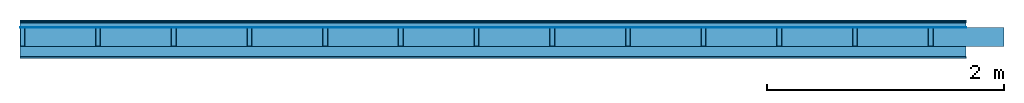
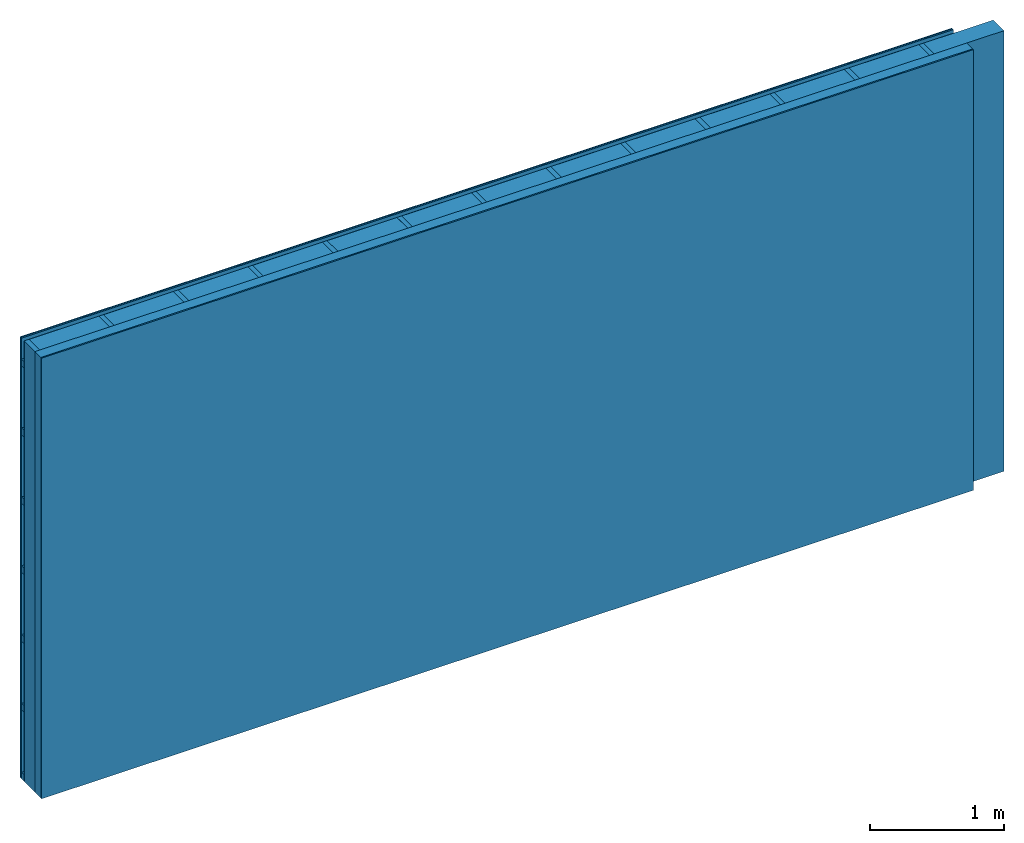
# One storey: 5 plates, 3 members, 1 element without a shape of its own.
"""IFC4 building model written with IfcOpenShell, lengths in metres."""

import ifcopenshell
import ifcopenshell.guid

model = None  # the IFC model being written
_history = None  # IfcOwnerHistory: only IFC2X3 demands one
_inside = {}  # id of a spatial element -> (the spatial element, [elements in it])
_under = {}  # id of a project, library or spatial element -> (it, [spatial elements below it])
_declared = {}  # id of a project -> (the project, [libraries it declares])
_typed = {}  # id of a type object -> (the type object, [elements of that type])
_made_of = {}  # id of a material, layer set ... -> (it, [elements and type objects made of it])


def new_model(schema):
    """Start an empty IFC model of exactly this schema.

    Asked for "IFC4X3", IfcOpenShell would pick the latest addendum, in which some entities
    have other attributes; the version numbers below select the first issue.
    IFC2X3 requires an IfcOwnerHistory on every rooted entity: one is made here for all.
    """
    global model, _history
    if schema == "IFC4X3":
        model = ifcopenshell.file(schema_version=(4, 3, 0, 0))
    else:
        model = ifcopenshell.file(schema=schema)
    _inside.clear()
    _under.clear()
    _declared.clear()
    _typed.clear()
    _made_of.clear()
    _history = None
    if model.schema == "IFC2X3":
        org = make("IfcOrganization", Name="unknown")
        user = make(
            "IfcPersonAndOrganization",
            ThePerson=make("IfcPerson", FamilyName="unknown"),
            TheOrganization=org,
        )
        app = make(
            "IfcApplication",
            ApplicationDeveloper=org,
            Version="unknown",
            ApplicationFullName="unknown",
            ApplicationIdentifier="unknown",
        )
        _history = make(
            "IfcOwnerHistory",
            OwningUser=user,
            OwningApplication=app,
            ChangeAction="ADDED",
            CreationDate=0,
        )
    return model


def make(cls, **values):
    """One entity of the class cls with the attributes given. An attribute that is None is left unset."""
    return model.create_entity(
        cls, **{name: value for name, value in values.items() if value is not None}
    )


def rooted(cls, **values):
    """An entity with a GlobalId (a new one), such as an element, a storey or a relation."""
    return make(cls, GlobalId=ifcopenshell.guid.new(), OwnerHistory=_history, **values)


def si_unit(unit_type, name, prefix=None):
    """IfcSIUnit, for example si_unit("LENGTHUNIT", "METRE", prefix="MILLI")."""
    return make("IfcSIUnit", UnitType=unit_type, Prefix=prefix, Name=name)


def derived_unit(unit_type, elements):
    """IfcDerivedUnit: a product of units, each with its exponent."""
    return make(
        "IfcDerivedUnit",
        Elements=[
            make("IfcDerivedUnitElement", Unit=unit, Exponent=power)
            for unit, power in elements
        ],
        UnitType=unit_type,
    )


def assignment(units):
    """IfcUnitAssignment: the units of a project."""
    return None if units is None else make("IfcUnitAssignment", Units=units)


def point(xyz):
    """IfcCartesianPoint."""
    return None if xyz is None else make("IfcCartesianPoint", Coordinates=xyz)


def direction(xyz):
    """IfcDirection."""
    return None if xyz is None else make("IfcDirection", DirectionRatios=xyz)


def frame(location, z_axis=None, x_axis=None):
    """IfcAxis2Placement3D, a coordinate frame: its origin and axes. An axis left out is left unset."""
    return make(
        "IfcAxis2Placement3D",
        Location=point(location),
        Axis=direction(z_axis),
        RefDirection=direction(x_axis),
    )


def frame_2d(location, x_axis=None):
    """IfcAxis2Placement2D, a coordinate frame in the plane: its origin and x axis."""
    return make(
        "IfcAxis2Placement2D", Location=point(location), RefDirection=direction(x_axis)
    )


def origin():
    """The frame at (0, 0, 0) with its axes left unset."""
    return frame((0.0, 0.0, 0.0))


def origin_with_axes():
    """The frame at (0, 0, 0) with the z axis (0, 0, 1) and the x axis (1, 0, 0) written out."""
    return frame((0.0, 0.0, 0.0), z_axis=(0.0, 0.0, 1.0), x_axis=(1.0, 0.0, 0.0))


def place(relative_to, where):
    """IfcLocalPlacement: puts the frame where relative to a parent placement (None: the world)."""
    return make(
        "IfcLocalPlacement", PlacementRelTo=relative_to, RelativePlacement=where
    )


def context(
    kind, dimensions, precision=None, world=None, true_north=None, identifier=None
):
    """IfcGeometricRepresentationContext, for example the 3D "Model" context."""
    return make(
        "IfcGeometricRepresentationContext",
        ContextIdentifier=identifier,
        ContextType=kind,
        CoordinateSpaceDimension=dimensions,
        Precision=precision,
        WorldCoordinateSystem=world,
        TrueNorth=true_north,
    )


def project(units=None, contexts=None):
    """IfcProject with its units and contexts."""
    return rooted(
        "IfcProject",
        Name="project",
        RepresentationContexts=contexts,
        UnitsInContext=assignment(units),
    )


def spatial(cls, under=None, at=None, **own):
    """A site, building, storey or space (cls), placed at a placement, below another one or the project."""
    s = rooted(cls, ObjectPlacement=at, **own)
    if under is not None:
        _under.setdefault(under.id(), (under, []))[1].append(s)
    return s


def profile(cls, at=None, kind="AREA", **sizes):
    """A parametric profile (cls). Its sizes go by their IFC names, for example OverallWidth=200.0."""
    return make(cls, ProfileType=kind, Position=at, **sizes)


def rectangle(**sizes):
    """IfcRectangleProfileDef."""
    return profile("IfcRectangleProfileDef", **sizes)


def extrude(swept, where, along, depth):
    """IfcExtrudedAreaSolid: the profile swept, set in the frame where, extruded along a direction by depth."""
    return make(
        "IfcExtrudedAreaSolid",
        SweptArea=swept,
        Position=where,
        ExtrudedDirection=direction(along),
        Depth=depth,
    )


def shape(context_of_items, identifier, shape_type, items):
    """IfcShapeRepresentation: the items that make up one representation, for example the "Body"."""
    return make(
        "IfcShapeRepresentation",
        ContextOfItems=context_of_items,
        RepresentationIdentifier=identifier,
        RepresentationType=shape_type,
        Items=items,
    )


def material(Name=None, Category=None):
    """IfcMaterial."""
    return make("IfcMaterial", Name=Name, Category=Category)


def layer(
    of_material, thickness, ventilated=None, Name=None, Category=None, Priority=None
):
    """IfcMaterialLayer: one layer of a wall or slab, of a material (None: an air gap)."""
    return make(
        "IfcMaterialLayer",
        Material=of_material,
        LayerThickness=thickness,
        IsVentilated=ventilated,
        Name=Name,
        Category=Category,
        Priority=Priority,
    )


def layer_set(layers, Name=None):
    """IfcMaterialLayerSet."""
    return make("IfcMaterialLayerSet", MaterialLayers=layers, LayerSetName=Name)


def made_of(thing, what):
    """Note that an element or type object is made of a material, layer set ...; save() writes the relation."""
    if what is not None:
        _made_of.setdefault(what.id(), (what, []))[1].append(thing)
    return thing


def type_object(cls, material=None, **own):
    """A type object (cls), such as IfcWallType, which elements share."""
    return made_of(rooted(cls, **own), material)


def element(
    cls,
    number,
    at=None,
    inside=None,
    cuts=None,
    type_object=None,
    material=None,
    context=None,
    identifier="Body",
    shape_type=None,
    held_by="IfcProductDefinitionShape",
    body=None,
    shapes=None,
    **own,
):
    """One element of the class cls, such as IfcWall. Its Tag is "e" and its number.

    at: its placement. inside: the storey or other place that contains it. cuts: it is an
    opening in that element (IfcRelVoidsElement). A single representation is given by context,
    identifier, shape_type and body (its items); several are given by shapes. held_by: the class
    of the entity that holds the representations. save() writes the other relations.
    """
    e = rooted(cls, Tag="e%d" % number, ObjectPlacement=at, **own)
    if body is not None:
        shapes = [shape(context, identifier, shape_type, body)]
    if shapes is not None:
        e.Representation = make(held_by, Representations=shapes)
    if inside is not None:
        _inside.setdefault(inside.id(), (inside, []))[1].append(e)
    if cuts is not None:
        rooted(
            "IfcRelVoidsElement", RelatingBuildingElement=cuts, RelatedOpeningElement=e
        )
    if type_object is not None:
        _typed.setdefault(type_object.id(), (type_object, []))[1].append(e)
    return made_of(e, material)


def aggregate(whole, parts):
    """IfcRelAggregates: a whole, such as a stair, and the parts it consists of."""
    return rooted("IfcRelAggregates", RelatingObject=whole, RelatedObjects=parts)


def save(model, path):
    """Write the relations noted so far, then the file.

    IfcRelAggregates (storeys below a building ...), IfcRelContainedInSpatialStructure (elements
    in a storey), IfcRelDefinesByType, IfcRelAssociatesMaterial and IfcRelDeclares: one each for
    every whole, place, type object, material and project.
    """
    for whole, parts in _under.values():
        aggregate(whole, parts)
    for where, things in _inside.values():
        rooted(
            "IfcRelContainedInSpatialStructure",
            RelatedElements=things,
            RelatingStructure=where,
        )
    for kind, things in _typed.values():
        rooted("IfcRelDefinesByType", RelatedObjects=things, RelatingType=kind)
    for what, things in _made_of.values():
        rooted("IfcRelAssociatesMaterial", RelatedObjects=things, RelatingMaterial=what)
    for by, libraries in _declared.values():
        rooted("IfcRelDeclares", RelatingContext=by, RelatedDefinitions=libraries)
    model.write(path)


model = new_model("IFC4")

# Units and contexts
plan_context = context("Plan", 3, precision=1e-05, world=origin(), true_north=direction((0.0, 1.0)))
model_context = context("Model", 3, precision=1e-05, world=origin(), true_north=direction((0.0, 1.0)))
ifc_project = project(units=[si_unit("LENGTHUNIT", "METRE"), derived_unit("SOUNDPRESSUREUNIT", [(si_unit("PRESSUREUNIT", "PASCAL", prefix="MICRO"), 0)]), si_unit("ENERGYUNIT", "JOULE", prefix="MEGA"), si_unit("MASSUNIT", "GRAM", prefix="KILO"), derived_unit("THERMALTRANSMITTANCEUNIT", [(si_unit("POWERUNIT", "WATT"), 1), (si_unit("AREAUNIT", "SQUARE_METRE"), -1), (si_unit("THERMODYNAMICTEMPERATUREUNIT", "KELVIN"), -1)]), derived_unit("AREADENSITYUNIT", [(si_unit("MASSUNIT", "GRAM", prefix="KILO"), 1), (si_unit("AREAUNIT", "SQUARE_METRE"), -1)]), derived_unit("USERDEFINED", [(si_unit("ENERGYUNIT", "JOULE", prefix="MEGA"), 1), (si_unit("AREAUNIT", "SQUARE_METRE"), -1)])], contexts=[plan_context, model_context])

# Site, building, storey
site = spatial("IfcSite", under=ifc_project)
building_placement = place(None, origin())
building = spatial("IfcBuilding", under=site, at=building_placement)
storey_placement = place(building_placement, origin())
storey = spatial("IfcBuildingStorey", under=building, at=storey_placement)

# Wall, members, plates
ifc_material_1 = material(Category="04.011")
ifc_layer_1 = layer(ifc_material_1, 0.01, Name="Surface 1")
ifc_material_2 = material(Name="mineral, cement-based building board", Category="03.003")
ifc_layer_2 = layer(ifc_material_2, 0.013, Name="Cover 1st layer")
ifc_layer_3 = layer(None, 0.04, Name="Battens / profiles (ventilation)")
ifc_material_3 = material(Name="Vapor-permeable water barrier", Category="09.006")
ifc_layer_4 = layer(ifc_material_3, 0.0005, Name="outside 1st layer")
ifc_material_4 = material(Name="of the art")
ifc_layer_5 = layer(ifc_material_4, 0.0, Name="Bond")
ifc_layer_6 = layer(None, 0.16, Name="Support")
ifc_layer_7 = layer(ifc_material_4, 0.0, Name="Bond")
ifc_material_5 = material(Name="Solid timber panel")
ifc_layer_8 = layer(ifc_material_5, 0.087, Name="1st layer")
ifc_material_6 = material(Name="Plasterboard type A", Category="03.008")
ifc_layer_9 = layer(ifc_material_6, 0.0125, Name="Covering 1st layer")
ifc_material_7 = material(Name="joints", Category="04.017")
ifc_layer_10 = layer(ifc_material_7, 0.0, Name="Surface")
ifc_layer_set = layer_set([ifc_layer_1, ifc_layer_2, ifc_layer_3, ifc_layer_4, ifc_layer_5, ifc_layer_6, ifc_layer_7, ifc_layer_8, ifc_layer_9, ifc_layer_10])
wall_type = type_object("IfcWallType", Name="D1004", PredefinedType="NOTDEFINED", material=ifc_layer_set)
wall_placement = place(None, frame((0.0, 0.0, 0.0), z_axis=(0.0, -1.0, 0.0), x_axis=(1.0, 0.0, 0.0)))
wall = element("IfcWall", 1, at=wall_placement, inside=storey, type_object=wall_type, material=ifc_layer_set, Name="Wall #1")
ifc_material_8 = material()
member_1_placement = place(wall_placement, origin())
member_1 = element("IfcMember", 2, at=member_1_placement, material=ifc_material_8, Name="Battens / profiles (ventilation)", context=plan_context, shape_type="SweptSolid", body=[
    extrude(rectangle(XDim=0.06, YDim=0.04, at=frame_2d((0.03, 0.02), x_axis=(1.0, 0.0))), frame((0.0, 0.0, 0.023), z_axis=(1.0, 0.0, 0.0), x_axis=(0.0, 1.0, 0.0)), (0.0, 0.0, 1.0), 8.0),
    extrude(rectangle(XDim=0.06, YDim=0.04, at=frame_2d((0.03, 0.02), x_axis=(1.0, 0.0))), frame((0.0, 0.625, 0.023), z_axis=(1.0, 0.0, 0.0), x_axis=(0.0, 1.0, 0.0)), (0.0, 0.0, 1.0), 8.0),
    extrude(rectangle(XDim=0.06, YDim=0.04, at=frame_2d((0.03, 0.02), x_axis=(1.0, 0.0))), frame((0.0, 1.25, 0.023), z_axis=(1.0, 0.0, 0.0), x_axis=(0.0, 1.0, 0.0)), (0.0, 0.0, 1.0), 8.0),
    extrude(rectangle(XDim=0.06, YDim=0.04, at=frame_2d((0.03, 0.02), x_axis=(1.0, 0.0))), frame((0.0, 1.875, 0.023), z_axis=(1.0, 0.0, 0.0), x_axis=(0.0, 1.0, 0.0)), (0.0, 0.0, 1.0), 8.0),
    extrude(rectangle(XDim=0.06, YDim=0.04, at=frame_2d((0.03, 0.02), x_axis=(1.0, 0.0))), frame((0.0, 2.5, 0.023), z_axis=(1.0, 0.0, 0.0), x_axis=(0.0, 1.0, 0.0)), (0.0, 0.0, 1.0), 8.0),
    extrude(rectangle(XDim=0.06, YDim=0.04, at=frame_2d((0.03, 0.02), x_axis=(1.0, 0.0))), frame((0.0, 3.125, 0.023), z_axis=(1.0, 0.0, 0.0), x_axis=(0.0, 1.0, 0.0)), (0.0, 0.0, 1.0), 8.0),
    extrude(rectangle(XDim=0.06, YDim=0.04, at=frame_2d((0.03, 0.02), x_axis=(1.0, 0.0))), frame((0.0, 3.75, 0.023), z_axis=(1.0, 0.0, 0.0), x_axis=(0.0, 1.0, 0.0)), (0.0, 0.0, 1.0), 8.0),
])
ifc_material_9 = material()
member_2_placement = place(wall_placement, origin())
member_2 = element("IfcMember", 3, at=member_2_placement, material=ifc_material_9, Name="Support", context=plan_context, shape_type="SweptSolid", body=[
    extrude(rectangle(XDim=0.04, YDim=0.16, at=frame_2d((0.02, 0.08), x_axis=(1.0, 0.0))), frame((0.0, 4.0, 0.0635), z_axis=(0.0, -1.0, 0.0), x_axis=(1.0, 0.0, 0.0)), (0.0, 0.0, 1.0), 4.0),
    extrude(rectangle(XDim=0.04, YDim=0.16, at=frame_2d((0.02, 0.08), x_axis=(1.0, 0.0))), frame((0.64, 4.0, 0.0635), z_axis=(0.0, -1.0, 0.0), x_axis=(1.0, 0.0, 0.0)), (0.0, 0.0, 1.0), 4.0),
    extrude(rectangle(XDim=0.04, YDim=0.16, at=frame_2d((0.02, 0.08), x_axis=(1.0, 0.0))), frame((1.28, 4.0, 0.0635), z_axis=(0.0, -1.0, 0.0), x_axis=(1.0, 0.0, 0.0)), (0.0, 0.0, 1.0), 4.0),
    extrude(rectangle(XDim=0.04, YDim=0.16, at=frame_2d((0.02, 0.08), x_axis=(1.0, 0.0))), frame((1.92, 4.0, 0.0635), z_axis=(0.0, -1.0, 0.0), x_axis=(1.0, 0.0, 0.0)), (0.0, 0.0, 1.0), 4.0),
    extrude(rectangle(XDim=0.04, YDim=0.16, at=frame_2d((0.02, 0.08), x_axis=(1.0, 0.0))), frame((2.56, 4.0, 0.0635), z_axis=(0.0, -1.0, 0.0), x_axis=(1.0, 0.0, 0.0)), (0.0, 0.0, 1.0), 4.0),
    extrude(rectangle(XDim=0.04, YDim=0.16, at=frame_2d((0.02, 0.08), x_axis=(1.0, 0.0))), frame((3.2, 4.0, 0.0635), z_axis=(0.0, -1.0, 0.0), x_axis=(1.0, 0.0, 0.0)), (0.0, 0.0, 1.0), 4.0),
    extrude(rectangle(XDim=0.04, YDim=0.16, at=frame_2d((0.02, 0.08), x_axis=(1.0, 0.0))), frame((3.84, 4.0, 0.0635), z_axis=(0.0, -1.0, 0.0), x_axis=(1.0, 0.0, 0.0)), (0.0, 0.0, 1.0), 4.0),
    extrude(rectangle(XDim=0.04, YDim=0.16, at=frame_2d((0.02, 0.08), x_axis=(1.0, 0.0))), frame((4.48, 4.0, 0.0635), z_axis=(0.0, -1.0, 0.0), x_axis=(1.0, 0.0, 0.0)), (0.0, 0.0, 1.0), 4.0),
    extrude(rectangle(XDim=0.04, YDim=0.16, at=frame_2d((0.02, 0.08), x_axis=(1.0, 0.0))), frame((5.12, 4.0, 0.0635), z_axis=(0.0, -1.0, 0.0), x_axis=(1.0, 0.0, 0.0)), (0.0, 0.0, 1.0), 4.0),
    extrude(rectangle(XDim=0.04, YDim=0.16, at=frame_2d((0.02, 0.08), x_axis=(1.0, 0.0))), frame((5.76, 4.0, 0.0635), z_axis=(0.0, -1.0, 0.0), x_axis=(1.0, 0.0, 0.0)), (0.0, 0.0, 1.0), 4.0),
    extrude(rectangle(XDim=0.04, YDim=0.16, at=frame_2d((0.02, 0.08), x_axis=(1.0, 0.0))), frame((6.4, 4.0, 0.0635), z_axis=(0.0, -1.0, 0.0), x_axis=(1.0, 0.0, 0.0)), (0.0, 0.0, 1.0), 4.0),
    extrude(rectangle(XDim=0.04, YDim=0.16, at=frame_2d((0.02, 0.08), x_axis=(1.0, 0.0))), frame((7.04, 4.0, 0.0635), z_axis=(0.0, -1.0, 0.0), x_axis=(1.0, 0.0, 0.0)), (0.0, 0.0, 1.0), 4.0),
    extrude(rectangle(XDim=0.04, YDim=0.16, at=frame_2d((0.02, 0.08), x_axis=(1.0, 0.0))), frame((7.68, 4.0, 0.0635), z_axis=(0.0, -1.0, 0.0), x_axis=(1.0, 0.0, 0.0)), (0.0, 0.0, 1.0), 4.0),
])
ifc_material_10 = material(Name="Mineral wool")
member_3_placement = place(wall_placement, origin())
member_3 = element("IfcMember", 4, at=member_3_placement, material=ifc_material_10, Name="Cavity", context=plan_context, shape_type="SweptSolid", body=[
    extrude(rectangle(XDim=0.6, YDim=0.16, at=frame_2d((0.3, 0.08), x_axis=(1.0, 0.0))), frame((0.04, 4.0, 0.0635), z_axis=(0.0, -1.0, 0.0), x_axis=(1.0, 0.0, 0.0)), (0.0, 0.0, 1.0), 4.0),
    extrude(rectangle(XDim=0.6, YDim=0.16, at=frame_2d((0.3, 0.08), x_axis=(1.0, 0.0))), frame((0.68, 4.0, 0.0635), z_axis=(0.0, -1.0, 0.0), x_axis=(1.0, 0.0, 0.0)), (0.0, 0.0, 1.0), 4.0),
    extrude(rectangle(XDim=0.6, YDim=0.16, at=frame_2d((0.3, 0.08), x_axis=(1.0, 0.0))), frame((1.32, 4.0, 0.0635), z_axis=(0.0, -1.0, 0.0), x_axis=(1.0, 0.0, 0.0)), (0.0, 0.0, 1.0), 4.0),
    extrude(rectangle(XDim=0.6, YDim=0.16, at=frame_2d((0.3, 0.08), x_axis=(1.0, 0.0))), frame((1.96, 4.0, 0.0635), z_axis=(0.0, -1.0, 0.0), x_axis=(1.0, 0.0, 0.0)), (0.0, 0.0, 1.0), 4.0),
    extrude(rectangle(XDim=0.6, YDim=0.16, at=frame_2d((0.3, 0.08), x_axis=(1.0, 0.0))), frame((2.6, 4.0, 0.0635), z_axis=(0.0, -1.0, 0.0), x_axis=(1.0, 0.0, 0.0)), (0.0, 0.0, 1.0), 4.0),
    extrude(rectangle(XDim=0.6, YDim=0.16, at=frame_2d((0.3, 0.08), x_axis=(1.0, 0.0))), frame((3.24, 4.0, 0.0635), z_axis=(0.0, -1.0, 0.0), x_axis=(1.0, 0.0, 0.0)), (0.0, 0.0, 1.0), 4.0),
    extrude(rectangle(XDim=0.6, YDim=0.16, at=frame_2d((0.3, 0.08), x_axis=(1.0, 0.0))), frame((3.88, 4.0, 0.0635), z_axis=(0.0, -1.0, 0.0), x_axis=(1.0, 0.0, 0.0)), (0.0, 0.0, 1.0), 4.0),
    extrude(rectangle(XDim=0.6, YDim=0.16, at=frame_2d((0.3, 0.08), x_axis=(1.0, 0.0))), frame((4.52, 4.0, 0.0635), z_axis=(0.0, -1.0, 0.0), x_axis=(1.0, 0.0, 0.0)), (0.0, 0.0, 1.0), 4.0),
    extrude(rectangle(XDim=0.6, YDim=0.16, at=frame_2d((0.3, 0.08), x_axis=(1.0, 0.0))), frame((5.16, 4.0, 0.0635), z_axis=(0.0, -1.0, 0.0), x_axis=(1.0, 0.0, 0.0)), (0.0, 0.0, 1.0), 4.0),
    extrude(rectangle(XDim=0.6, YDim=0.16, at=frame_2d((0.3, 0.08), x_axis=(1.0, 0.0))), frame((5.8, 4.0, 0.0635), z_axis=(0.0, -1.0, 0.0), x_axis=(1.0, 0.0, 0.0)), (0.0, 0.0, 1.0), 4.0),
    extrude(rectangle(XDim=0.6, YDim=0.16, at=frame_2d((0.3, 0.08), x_axis=(1.0, 0.0))), frame((6.44, 4.0, 0.0635), z_axis=(0.0, -1.0, 0.0), x_axis=(1.0, 0.0, 0.0)), (0.0, 0.0, 1.0), 4.0),
    extrude(rectangle(XDim=0.6, YDim=0.16, at=frame_2d((0.3, 0.08), x_axis=(1.0, 0.0))), frame((7.08, 4.0, 0.0635), z_axis=(0.0, -1.0, 0.0), x_axis=(1.0, 0.0, 0.0)), (0.0, 0.0, 1.0), 4.0),
    extrude(rectangle(XDim=0.6, YDim=0.16, at=frame_2d((0.3, 0.08), x_axis=(1.0, 0.0))), frame((7.72, 4.0, 0.0635), z_axis=(0.0, -1.0, 0.0), x_axis=(1.0, 0.0, 0.0)), (0.0, 0.0, 1.0), 4.0),
])
plate_1_placement = place(wall_placement, origin())
plate_1 = element("IfcPlate", 5, at=plate_1_placement, material=ifc_material_1, Name="Surface 1", context=plan_context, shape_type="SweptSolid", body=[
    extrude(rectangle(XDim=8.0, YDim=4.0, at=frame_2d((4.0, 2.0), x_axis=(1.0, 0.0))), origin_with_axes(), (0.0, 0.0, 1.0), 0.01),
])
plate_2_placement = place(wall_placement, origin())
plate_2 = element("IfcPlate", 6, at=plate_2_placement, material=ifc_material_2, Name="Cover 1st layer", context=plan_context, shape_type="SweptSolid", body=[
    extrude(rectangle(XDim=8.0, YDim=4.0, at=frame_2d((4.0, 2.0), x_axis=(1.0, 0.0))), frame((0.0, 0.0, 0.01), z_axis=(0.0, 0.0, 1.0), x_axis=(1.0, 0.0, 0.0)), (0.0, 0.0, 1.0), 0.013),
])
plate_3_placement = place(wall_placement, origin())
plate_3 = element("IfcPlate", 7, at=plate_3_placement, material=ifc_material_3, Name="outside 1st layer", context=plan_context, shape_type="SweptSolid", body=[
    extrude(rectangle(XDim=8.0, YDim=4.0, at=frame_2d((4.0, 2.0), x_axis=(1.0, 0.0))), frame((0.0, 0.0, 0.063), z_axis=(0.0, 0.0, 1.0), x_axis=(1.0, 0.0, 0.0)), (0.0, 0.0, 1.0), 0.0005),
])
plate_4_placement = place(wall_placement, origin())
plate_4 = element("IfcPlate", 8, at=plate_4_placement, material=ifc_material_5, Name="1st layer", context=plan_context, shape_type="SweptSolid", body=[
    extrude(rectangle(XDim=8.0, YDim=4.0, at=frame_2d((4.0, 2.0), x_axis=(1.0, 0.0))), frame((0.0, 0.0, 0.2235), z_axis=(0.0, 0.0, 1.0), x_axis=(1.0, 0.0, 0.0)), (0.0, 0.0, 1.0), 0.087),
])
plate_5_placement = place(wall_placement, origin())
plate_5 = element("IfcPlate", 9, at=plate_5_placement, material=ifc_material_6, Name="Covering 1st layer", context=plan_context, shape_type="SweptSolid", body=[
    extrude(rectangle(XDim=8.0, YDim=4.0, at=frame_2d((4.0, 2.0), x_axis=(1.0, 0.0))), frame((0.0, 0.0, 0.3105), z_axis=(0.0, 0.0, 1.0), x_axis=(1.0, 0.0, 0.0)), (0.0, 0.0, 1.0), 0.0125),
])
aggregate(wall, [plate_1, plate_2, member_1, plate_3, member_2, member_3, plate_4, plate_5])

save(model, "model.ifc")
